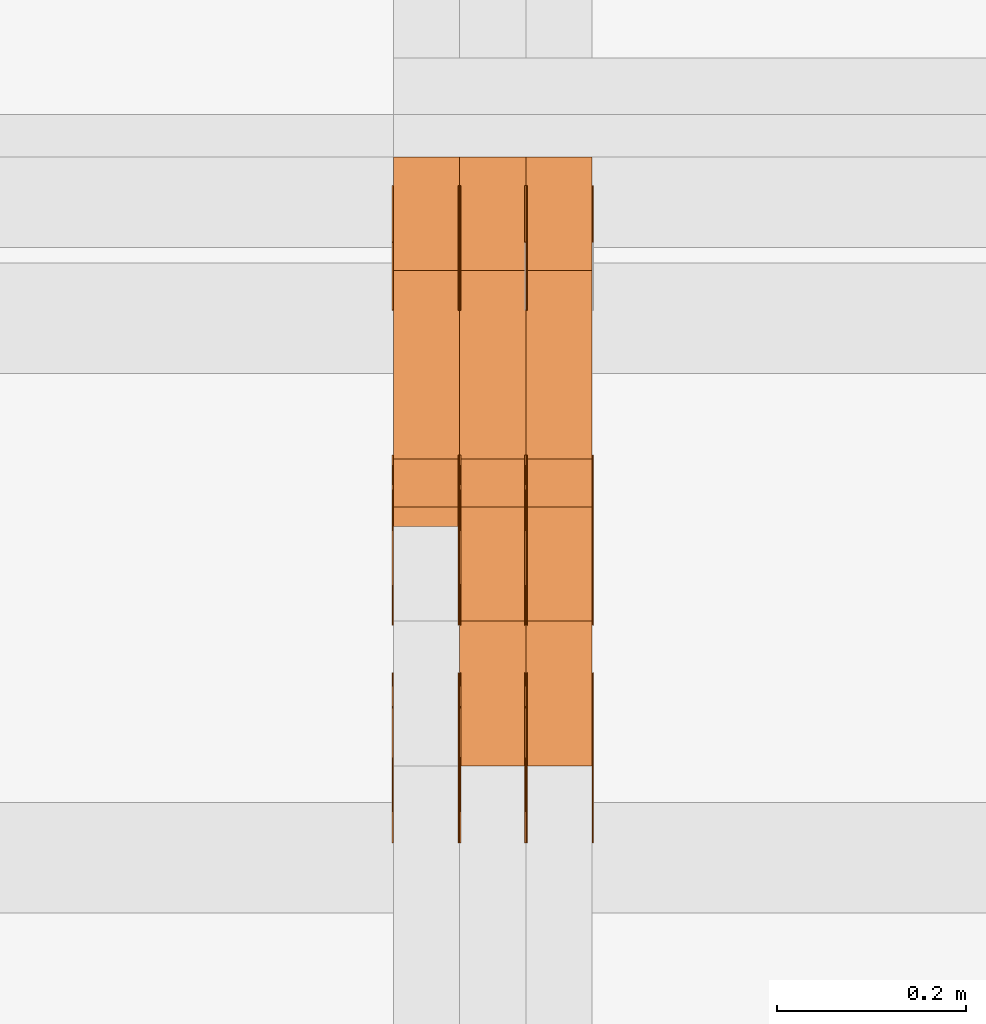
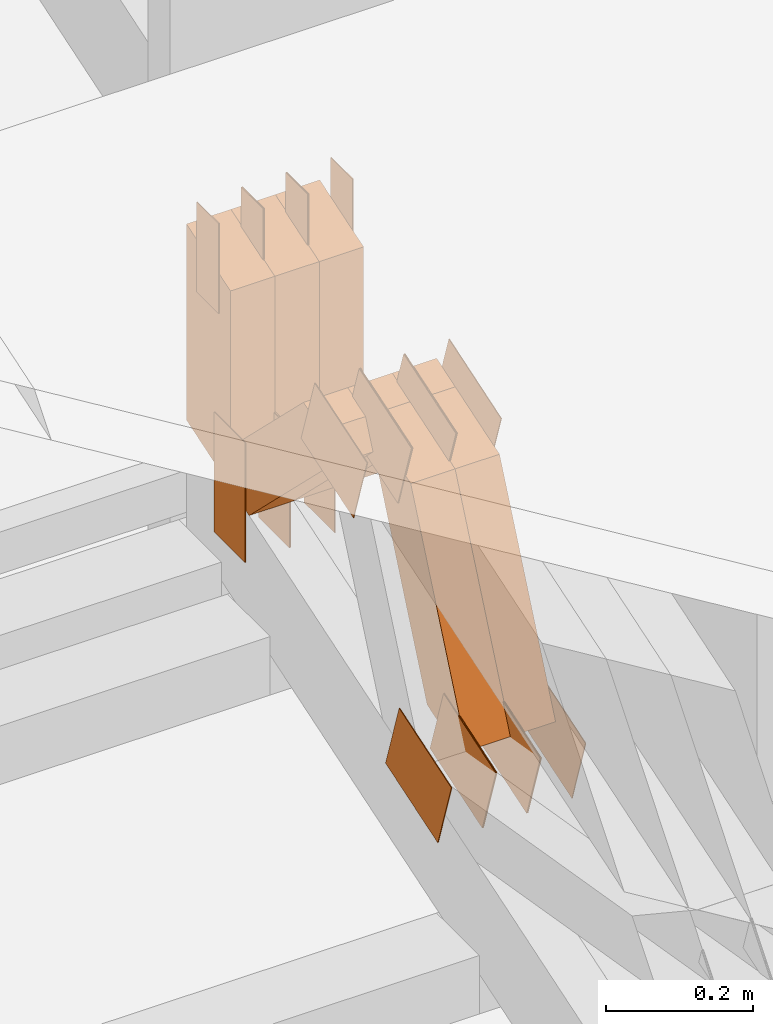
# One storey, part 92 of 385: 30 proxies.
"""IFC2X3 building model written with IfcOpenShell, lengths in millimetres."""

from ifc_helpers import new_model, entity, si_unit, converted_unit, derived_unit, direction, frame, frame_2d, origin, origin_2d_with_axis, place, context, subcontext, project, spatial, polyline, rectangle, outline, extrude, source, transform, mapped, material, type_object, type_shapes, element, save


model = new_model("IFC2X3")

# Units and contexts
model_context = context("Model", 3, precision=0.01, world=origin(), true_north=direction((6.12303176911189e-17, 1.0)))
body_context = subcontext(model_context, "Body", "Model", "MODEL_VIEW")
ifc_project = project(units=[si_unit("LENGTHUNIT", "METRE", prefix="MILLI"), si_unit("AREAUNIT", "SQUARE_METRE"), si_unit("VOLUMEUNIT", "CUBIC_METRE"), converted_unit("PLANEANGLEUNIT", "DEGREE", entity("IfcRatioMeasure", 0.0174532925199433), si_unit("PLANEANGLEUNIT", "RADIAN"), dimensions=[0, 0, 0, 0, 0, 0, 0]), si_unit("MASSUNIT", "GRAM", prefix="KILO"), derived_unit("MASSDENSITYUNIT", [(si_unit("MASSUNIT", "GRAM", prefix="KILO"), 1), (si_unit("LENGTHUNIT", "METRE"), -3)]), si_unit("TIMEUNIT", "SECOND"), si_unit("FREQUENCYUNIT", "HERTZ"), si_unit("THERMODYNAMICTEMPERATUREUNIT", "DEGREE_CELSIUS"), derived_unit("THERMALTRANSMITTANCEUNIT", [(si_unit("MASSUNIT", "GRAM", prefix="KILO"), 1), (si_unit("THERMODYNAMICTEMPERATUREUNIT", "KELVIN"), -1), (si_unit("TIMEUNIT", "SECOND"), -3)]), derived_unit("VOLUMETRICFLOWRATEUNIT", [(si_unit("LENGTHUNIT", "METRE"), 3), (si_unit("TIMEUNIT", "SECOND"), -1)]), si_unit("ELECTRICCURRENTUNIT", "AMPERE"), si_unit("ELECTRICVOLTAGEUNIT", "VOLT"), si_unit("POWERUNIT", "WATT"), si_unit("FORCEUNIT", "NEWTON", prefix="KILO"), si_unit("ILLUMINANCEUNIT", "LUX"), si_unit("LUMINOUSFLUXUNIT", "LUMEN"), si_unit("LUMINOUSINTENSITYUNIT", "CANDELA"), derived_unit("USERDEFINED", [(si_unit("MASSUNIT", "GRAM", prefix="KILO"), -1), (si_unit("LENGTHUNIT", "METRE"), -2), (si_unit("TIMEUNIT", "SECOND"), 3), (si_unit("LUMINOUSFLUXUNIT", "LUMEN"), 1)]), derived_unit("LINEARVELOCITYUNIT", [(si_unit("LENGTHUNIT", "METRE"), 1), (si_unit("TIMEUNIT", "SECOND"), -1)]), si_unit("PRESSUREUNIT", "PASCAL"), derived_unit("USERDEFINED", [(si_unit("LENGTHUNIT", "METRE"), -2), (si_unit("MASSUNIT", "GRAM", prefix="KILO"), 1), (si_unit("TIMEUNIT", "SECOND"), -2)])], contexts=[model_context])

# Site, building, storey
site_placement = place(None, origin())
site = spatial("IfcSite", under=ifc_project, at=site_placement, CompositionType="ELEMENT")
building_placement = place(site_placement, origin())
building = spatial("IfcBuilding", under=site, at=building_placement, CompositionType="ELEMENT")
storey_placement = place(building_placement, origin())
storey = spatial("IfcBuildingStorey", under=building, at=storey_placement, Name="Default", CompositionType="ELEMENT", Elevation=0.0)

# Proxies
ifc_material_1 = material(Name="IfcSurfaceStyle #140162")
building_element_proxy_type_1 = type_object("IfcBuildingElementProxyType", PredefinedType="NOTDEFINED", material=ifc_material_1)
shared_shape_1 = source(origin(), body_context, "Body", "SweptSolid", [
    extrude(rectangle(XDim=200.0, YDim=84.0, at=frame_2d((0.0, -7.105427357601e-15), x_axis=(1.0, 0.0))), frame((100.0, 42.0, 0.0), z_axis=(0.0, 0.0, 1.0), x_axis=(-1.0, 0.0, 0.0)), (0.0, 0.0, 1.0), 1.3),
])
type_shapes(building_element_proxy_type_1, [shared_shape_1])
proxy_1_placement = place(building_placement, frame((9316.29999999998, 13702.0, 3651.4150390625), z_axis=(-1.0, 0.0, 0.0), x_axis=(0.0, 0.0, -1.0)))
element("IfcBuildingElementProxy", 1, at=proxy_1_placement, inside=storey, type_object=building_element_proxy_type_1, material=ifc_material_1, context=body_context, shape_type="MappedRepresentation", body=[
    mapped(shared_shape_1, transform((0.0, 0.0, 0.0), scale=1.0)),
])
ifc_material_2 = material(Name="IfcSurfaceStyle #140105")
building_element_proxy_type_2 = type_object("IfcBuildingElementProxyType", PredefinedType="NOTDEFINED", material=ifc_material_2)
shared_shape_2 = source(origin(), body_context, "Body", "SweptSolid", [
    extrude(rectangle(XDim=200.0, YDim=84.0, at=frame_2d((0.0, -7.105427357601e-15), x_axis=(1.0, 0.0))), frame((100.0, 42.0, 0.0), z_axis=(0.0, 0.0, 1.0), x_axis=(-1.0, 0.0, 0.0)), (0.0, 0.0, 1.0), 1.29999999999998),
])
type_shapes(building_element_proxy_type_2, [shared_shape_2])
proxy_2_placement = place(building_placement, frame((9245.0, 13702.0, 3651.4150390625), z_axis=(-1.0, 0.0, 0.0), x_axis=(0.0, 0.0, -1.0)))
element("IfcBuildingElementProxy", 2, at=proxy_2_placement, inside=storey, type_object=building_element_proxy_type_2, material=ifc_material_2, context=body_context, shape_type="MappedRepresentation", body=[
    mapped(shared_shape_2, transform((0.0, 0.0, 0.0), scale=1.0)),
])
ifc_material_3 = material(Name="IfcSurfaceStyle #140048")
building_element_proxy_type_3 = type_object("IfcBuildingElementProxyType", PredefinedType="NOTDEFINED", material=ifc_material_3)
shared_shape_3 = source(origin(), body_context, "Body", "SweptSolid", [
    extrude(rectangle(XDim=200.0, YDim=84.0, at=frame_2d((0.0, -7.105427357601e-15), x_axis=(1.0, 0.0))), frame((100.0, 42.0, 0.0), z_axis=(0.0, 0.0, 1.0), x_axis=(-1.0, 0.0, 0.0)), (0.0, 0.0, 1.0), 1.29999999999998),
])
type_shapes(building_element_proxy_type_3, [shared_shape_3])
proxy_3_placement = place(building_placement, frame((9246.29999999998, 13702.0, 3651.4150390625), z_axis=(-1.0, 0.0, 0.0), x_axis=(0.0, 0.0, -1.0)))
element("IfcBuildingElementProxy", 3, at=proxy_3_placement, inside=storey, type_object=building_element_proxy_type_3, material=ifc_material_3, context=body_context, shape_type="MappedRepresentation", body=[
    mapped(shared_shape_3, transform((0.0, 0.0, 0.0), scale=1.0)),
])
ifc_material_4 = material(Name="IfcSurfaceStyle #139991")
building_element_proxy_type_4 = type_object("IfcBuildingElementProxyType", PredefinedType="NOTDEFINED", material=ifc_material_4)
shared_shape_4 = source(origin(), body_context, "Body", "SweptSolid", [
    extrude(rectangle(XDim=200.0, YDim=84.0, at=frame_2d((0.0, -7.105427357601e-15), x_axis=(1.0, 0.0))), frame((100.0, 42.0, 0.0), z_axis=(0.0, 0.0, 1.0), x_axis=(-1.0, 0.0, 0.0)), (0.0, 0.0, 1.0), 1.29999999999999),
])
type_shapes(building_element_proxy_type_4, [shared_shape_4])
proxy_4_placement = place(building_placement, frame((9175.0, 13702.0, 3651.4150390625), z_axis=(-1.0, 0.0, 0.0), x_axis=(0.0, 0.0, -1.0)))
element("IfcBuildingElementProxy", 4, at=proxy_4_placement, inside=storey, type_object=building_element_proxy_type_4, material=ifc_material_4, context=body_context, shape_type="MappedRepresentation", body=[
    mapped(shared_shape_4, transform((0.0, 0.0, 0.0), scale=1.0)),
])
ifc_material_5 = material(Name="IfcSurfaceStyle #139934")
building_element_proxy_type_5 = type_object("IfcBuildingElementProxyType", PredefinedType="NOTDEFINED", material=ifc_material_5)
shared_shape_5 = source(origin(), body_context, "Body", "SweptSolid", [
    extrude(outline(polyline([(-75.0003398116828, -59.9998507501386), (75.0003249421766, -59.9998507501386), (75.0003398116837, 59.9998507501387), (-75.0003249421775, 59.9998507501387), (-75.0003398116828, -59.9998507501386)])), frame((75.0003398116837, 60.0000773549637, 0.0), z_axis=(0.0, 0.0, 1.0), x_axis=(-1.0, 0.0, 0.0)), (0.0, 0.0, 1.0), 1.3),
])
type_shapes(building_element_proxy_type_5, [shared_shape_5])
proxy_5_placement = place(building_placement, frame((9386.29999999998, 13054.73046875, 3417.8388671875), z_axis=(-1.0, 0.0, 0.0), x_axis=(0.0, 0.951056516295124, 0.309016994375039)))
element("IfcBuildingElementProxy", 5, at=proxy_5_placement, inside=storey, type_object=building_element_proxy_type_5, material=ifc_material_5, context=body_context, shape_type="MappedRepresentation", body=[
    mapped(shared_shape_5, transform((0.0, 0.0, 0.0), scale=1.0)),
])
ifc_material_6 = material(Name="IfcSurfaceStyle #139877")
building_element_proxy_type_6 = type_object("IfcBuildingElementProxyType", PredefinedType="NOTDEFINED", material=ifc_material_6)
shared_shape_6 = source(origin(), body_context, "Body", "SweptSolid", [
    extrude(outline(polyline([(-75.0003398116828, -59.9998507501386), (75.0003249421766, -59.9998507501386), (75.0003398116837, 59.9998507501387), (-75.0003249421775, 59.9998507501387), (-75.0003398116828, -59.9998507501386)])), frame((75.0003398116837, 60.0000773549637, 0.0), z_axis=(0.0, 0.0, 1.0), x_axis=(-1.0, 0.0, 0.0)), (0.0, 0.0, 1.0), 1.3),
])
type_shapes(building_element_proxy_type_6, [shared_shape_6])
proxy_6_placement = place(building_placement, frame((9315.0, 13054.73046875, 3417.8388671875), z_axis=(-1.0, 0.0, 0.0), x_axis=(0.0, 0.951056516295124, 0.309016994375039)))
element("IfcBuildingElementProxy", 6, at=proxy_6_placement, inside=storey, type_object=building_element_proxy_type_6, material=ifc_material_6, context=body_context, shape_type="MappedRepresentation", body=[
    mapped(shared_shape_6, transform((0.0, 0.0, 0.0), scale=1.0)),
])
ifc_material_7 = material(Name="IfcSurfaceStyle #139820")
building_element_proxy_type_7 = type_object("IfcBuildingElementProxyType", PredefinedType="NOTDEFINED", material=ifc_material_7)
shared_shape_7 = source(origin(), body_context, "Body", "SweptSolid", [
    extrude(outline(polyline([(-75.0003398116828, -59.9998507501386), (75.0003249421766, -59.9998507501386), (75.0003398116837, 59.9998507501387), (-75.0003249421775, 59.9998507501387), (-75.0003398116828, -59.9998507501386)])), frame((75.0003398116837, 60.0000773549637, 0.0), z_axis=(0.0, 0.0, 1.0), x_axis=(-1.0, 0.0, 0.0)), (0.0, 0.0, 1.0), 1.3),
])
type_shapes(building_element_proxy_type_7, [shared_shape_7])
proxy_7_placement = place(building_placement, frame((9316.29999999998, 13054.73046875, 3417.8388671875), z_axis=(-1.0, 0.0, 0.0), x_axis=(0.0, 0.951056516295124, 0.309016994375039)))
element("IfcBuildingElementProxy", 7, at=proxy_7_placement, inside=storey, type_object=building_element_proxy_type_7, material=ifc_material_7, context=body_context, shape_type="MappedRepresentation", body=[
    mapped(shared_shape_7, transform((0.0, 0.0, 0.0), scale=1.0)),
])
ifc_material_8 = material(Name="IfcSurfaceStyle #139763")
building_element_proxy_type_8 = type_object("IfcBuildingElementProxyType", PredefinedType="NOTDEFINED", material=ifc_material_8)
shared_shape_8 = source(origin(), body_context, "Body", "SweptSolid", [
    extrude(outline(polyline([(-75.0003398116828, -59.9998507501386), (75.0003249421766, -59.9998507501386), (75.0003398116837, 59.9998507501387), (-75.0003249421775, 59.9998507501387), (-75.0003398116828, -59.9998507501386)])), frame((75.0003398116837, 60.0000773549637, 0.0), z_axis=(0.0, 0.0, 1.0), x_axis=(-1.0, 0.0, 0.0)), (0.0, 0.0, 1.0), 1.29999999999999),
])
type_shapes(building_element_proxy_type_8, [shared_shape_8])
proxy_8_placement = place(building_placement, frame((9245.0, 13054.73046875, 3417.8388671875), z_axis=(-1.0, 0.0, 0.0), x_axis=(0.0, 0.951056516295124, 0.309016994375039)))
element("IfcBuildingElementProxy", 8, at=proxy_8_placement, inside=storey, type_object=building_element_proxy_type_8, material=ifc_material_8, context=body_context, shape_type="MappedRepresentation", body=[
    mapped(shared_shape_8, transform((0.0, 0.0, 0.0), scale=1.0)),
])
ifc_material_9 = material(Name="IfcSurfaceStyle #139706")
building_element_proxy_type_9 = type_object("IfcBuildingElementProxyType", PredefinedType="NOTDEFINED", material=ifc_material_9)
shared_shape_9 = source(origin(), body_context, "Body", "SweptSolid", [
    extrude(outline(polyline([(-75.0003398116828, -59.9998507501386), (75.0003249421766, -59.9998507501386), (75.0003398116837, 59.9998507501387), (-75.0003249421775, 59.9998507501387), (-75.0003398116828, -59.9998507501386)])), frame((75.0003398116837, 60.0000773549637, 0.0), z_axis=(0.0, 0.0, 1.0), x_axis=(-1.0, 0.0, 0.0)), (0.0, 0.0, 1.0), 1.29999999999999),
])
type_shapes(building_element_proxy_type_9, [shared_shape_9])
proxy_9_placement = place(building_placement, frame((9246.29999999998, 13054.73046875, 3417.8388671875), z_axis=(-1.0, 0.0, 0.0), x_axis=(0.0, 0.951056516295124, 0.309016994375039)))
element("IfcBuildingElementProxy", 9, at=proxy_9_placement, inside=storey, type_object=building_element_proxy_type_9, material=ifc_material_9, context=body_context, shape_type="MappedRepresentation", body=[
    mapped(shared_shape_9, transform((0.0, 0.0, 0.0), scale=1.0)),
])
ifc_material_10 = material(Name="IfcSurfaceStyle #139649")
building_element_proxy_type_10 = type_object("IfcBuildingElementProxyType", PredefinedType="NOTDEFINED", material=ifc_material_10)
shared_shape_10 = source(origin(), body_context, "Body", "SweptSolid", [
    extrude(outline(polyline([(-75.0003398116828, -59.9998507501386), (75.0003249421766, -59.9998507501386), (75.0003398116837, 59.9998507501387), (-75.0003249421775, 59.9998507501387), (-75.0003398116828, -59.9998507501386)])), frame((75.0003398116837, 60.0000773549637, 0.0), z_axis=(0.0, 0.0, 1.0), x_axis=(-1.0, 0.0, 0.0)), (0.0, 0.0, 1.0), 1.29999999999999),
])
type_shapes(building_element_proxy_type_10, [shared_shape_10])
proxy_10_placement = place(building_placement, frame((9175.0, 13054.73046875, 3417.8388671875), z_axis=(-1.0, 0.0, 0.0), x_axis=(0.0, 0.951056516295124, 0.309016994375039)))
element("IfcBuildingElementProxy", 10, at=proxy_10_placement, inside=storey, type_object=building_element_proxy_type_10, material=ifc_material_10, context=body_context, shape_type="MappedRepresentation", body=[
    mapped(shared_shape_10, transform((0.0, 0.0, 0.0), scale=1.0)),
])
ifc_material_11 = material(Name="IfcSurfaceStyle #132068")
building_element_proxy_type_11 = type_object("IfcBuildingElementProxyType", PredefinedType="NOTDEFINED", material=ifc_material_11)
shared_shape_11 = source(origin(), body_context, "Body", "SweptSolid", [
    extrude(outline(polyline([(-74.999875428623, -60.0000016373506), (74.9998605591059, -60.0000016373506), (74.9998754286239, 60.0000016373506), (-74.9998605591068, 60.0000016373506), (-74.999875428623, -60.0000016373506)])), frame((75.0002691827262, 60.0000190504561, 0.0), z_axis=(0.0, 0.0, 1.0), x_axis=(-1.0, 0.0, 0.0)), (0.0, 0.0, 1.0), 1.3),
])
type_shapes(building_element_proxy_type_11, [shared_shape_11])
proxy_11_placement = place(building_placement, frame((9386.29999999998, 13285.0865109705, 3819.37496637467), z_axis=(-1.0, 0.0, 0.0), x_axis=(0.0, 0.951056516295154, 0.309016994374948)))
element("IfcBuildingElementProxy", 11, at=proxy_11_placement, inside=storey, type_object=building_element_proxy_type_11, material=ifc_material_11, context=body_context, shape_type="MappedRepresentation", body=[
    mapped(shared_shape_11, transform((0.0, 0.0, 0.0), scale=1.0)),
])
ifc_material_12 = material(Name="IfcSurfaceStyle #132011")
building_element_proxy_type_12 = type_object("IfcBuildingElementProxyType", PredefinedType="NOTDEFINED", material=ifc_material_12)
shared_shape_12 = source(origin(), body_context, "Body", "SweptSolid", [
    extrude(outline(polyline([(-74.999875428623, -60.0000016373506), (74.9998605591059, -60.0000016373506), (74.9998754286239, 60.0000016373506), (-74.9998605591068, 60.0000016373506), (-74.999875428623, -60.0000016373506)])), frame((75.0002691827262, 60.0000190504561, 0.0), z_axis=(0.0, 0.0, 1.0), x_axis=(-1.0, 0.0, 0.0)), (0.0, 0.0, 1.0), 1.3),
])
type_shapes(building_element_proxy_type_12, [shared_shape_12])
proxy_12_placement = place(building_placement, frame((9315.0, 13285.0865109705, 3819.37496637467), z_axis=(-1.0, 0.0, 0.0), x_axis=(0.0, 0.951056516295154, 0.309016994374948)))
element("IfcBuildingElementProxy", 12, at=proxy_12_placement, inside=storey, type_object=building_element_proxy_type_12, material=ifc_material_12, context=body_context, shape_type="MappedRepresentation", body=[
    mapped(shared_shape_12, transform((0.0, 0.0, 0.0), scale=1.0)),
])
ifc_material_13 = material(Name="IfcSurfaceStyle #131954")
building_element_proxy_type_13 = type_object("IfcBuildingElementProxyType", PredefinedType="NOTDEFINED", material=ifc_material_13)
shared_shape_13 = source(origin(), body_context, "Body", "SweptSolid", [
    extrude(outline(polyline([(-74.999875428623, -60.0000016373506), (74.9998605591059, -60.0000016373506), (74.9998754286239, 60.0000016373506), (-74.9998605591068, 60.0000016373506), (-74.999875428623, -60.0000016373506)])), frame((75.0002691827262, 60.0000190504561, 0.0), z_axis=(0.0, 0.0, 1.0), x_axis=(-1.0, 0.0, 0.0)), (0.0, 0.0, 1.0), 1.3),
])
type_shapes(building_element_proxy_type_13, [shared_shape_13])
proxy_13_placement = place(building_placement, frame((9316.29999999998, 13285.0865109705, 3819.37496637467), z_axis=(-1.0, 0.0, 0.0), x_axis=(0.0, 0.951056516295154, 0.309016994374948)))
element("IfcBuildingElementProxy", 13, at=proxy_13_placement, inside=storey, type_object=building_element_proxy_type_13, material=ifc_material_13, context=body_context, shape_type="MappedRepresentation", body=[
    mapped(shared_shape_13, transform((0.0, 0.0, 0.0), scale=1.0)),
])
ifc_material_14 = material(Name="IfcSurfaceStyle #131897")
building_element_proxy_type_14 = type_object("IfcBuildingElementProxyType", PredefinedType="NOTDEFINED", material=ifc_material_14)
shared_shape_14 = source(origin(), body_context, "Body", "SweptSolid", [
    extrude(outline(polyline([(-74.999875428623, -60.0000016373506), (74.9998605591059, -60.0000016373506), (74.9998754286239, 60.0000016373506), (-74.9998605591068, 60.0000016373506), (-74.999875428623, -60.0000016373506)])), frame((75.0002691827262, 60.0000190504561, 0.0), z_axis=(0.0, 0.0, 1.0), x_axis=(-1.0, 0.0, 0.0)), (0.0, 0.0, 1.0), 1.29999999999999),
])
type_shapes(building_element_proxy_type_14, [shared_shape_14])
proxy_14_placement = place(building_placement, frame((9245.0, 13285.0865109705, 3819.37496637467), z_axis=(-1.0, 0.0, 0.0), x_axis=(0.0, 0.951056516295154, 0.309016994374948)))
element("IfcBuildingElementProxy", 14, at=proxy_14_placement, inside=storey, type_object=building_element_proxy_type_14, material=ifc_material_14, context=body_context, shape_type="MappedRepresentation", body=[
    mapped(shared_shape_14, transform((0.0, 0.0, 0.0), scale=1.0)),
])
ifc_material_15 = material(Name="IfcSurfaceStyle #131840")
building_element_proxy_type_15 = type_object("IfcBuildingElementProxyType", PredefinedType="NOTDEFINED", material=ifc_material_15)
shared_shape_15 = source(origin(), body_context, "Body", "SweptSolid", [
    extrude(outline(polyline([(-74.999875428623, -60.0000016373506), (74.9998605591059, -60.0000016373506), (74.9998754286239, 60.0000016373506), (-74.9998605591068, 60.0000016373506), (-74.999875428623, -60.0000016373506)])), frame((75.0002691827262, 60.0000190504561, 0.0), z_axis=(0.0, 0.0, 1.0), x_axis=(-1.0, 0.0, 0.0)), (0.0, 0.0, 1.0), 1.29999999999999),
])
type_shapes(building_element_proxy_type_15, [shared_shape_15])
proxy_15_placement = place(building_placement, frame((9246.29999999998, 13285.0865109705, 3819.37496637467), z_axis=(-1.0, 0.0, 0.0), x_axis=(0.0, 0.951056516295154, 0.309016994374948)))
element("IfcBuildingElementProxy", 15, at=proxy_15_placement, inside=storey, type_object=building_element_proxy_type_15, material=ifc_material_15, context=body_context, shape_type="MappedRepresentation", body=[
    mapped(shared_shape_15, transform((0.0, 0.0, 0.0), scale=1.0)),
])
ifc_material_16 = material(Name="IfcSurfaceStyle #131783")
building_element_proxy_type_16 = type_object("IfcBuildingElementProxyType", PredefinedType="NOTDEFINED", material=ifc_material_16)
shared_shape_16 = source(origin(), body_context, "Body", "SweptSolid", [
    extrude(outline(polyline([(-74.999875428623, -60.0000016373506), (74.9998605591059, -60.0000016373506), (74.9998754286239, 60.0000016373506), (-74.9998605591068, 60.0000016373506), (-74.999875428623, -60.0000016373506)])), frame((75.0002691827262, 60.0000190504561, 0.0), z_axis=(0.0, 0.0, 1.0), x_axis=(-1.0, 0.0, 0.0)), (0.0, 0.0, 1.0), 1.29999999999999),
])
type_shapes(building_element_proxy_type_16, [shared_shape_16])
proxy_16_placement = place(building_placement, frame((9175.0, 13285.0865109705, 3819.37496637467), z_axis=(-1.0, 0.0, 0.0), x_axis=(0.0, 0.951056516295154, 0.309016994374948)))
element("IfcBuildingElementProxy", 16, at=proxy_16_placement, inside=storey, type_object=building_element_proxy_type_16, material=ifc_material_16, context=body_context, shape_type="MappedRepresentation", body=[
    mapped(shared_shape_16, transform((0.0, 0.0, 0.0), scale=1.0)),
])
ifc_material_17 = material(Name="IfcSurfaceStyle #131384")
building_element_proxy_type_17 = type_object("IfcBuildingElementProxyType", PredefinedType="NOTDEFINED", material=ifc_material_17)
shared_shape_17 = source(origin(), body_context, "Body", "SweptSolid", [
    extrude(rectangle(XDim=150.0, YDim=60.0, at=origin_2d_with_axis()), frame((75.0000705696166, 30.0, 0.0), z_axis=(0.0, 0.0, 1.0), x_axis=(-1.0, 0.0, 0.0)), (0.0, 0.0, 1.0), 1.3),
])
type_shapes(building_element_proxy_type_17, [shared_shape_17])
proxy_17_placement = place(building_placement, frame((9386.29999999998, 13750.0, 3972.59919166337), z_axis=(-1.0, 0.0, 0.0), x_axis=(0.0, 0.0, -1.0)))
element("IfcBuildingElementProxy", 17, at=proxy_17_placement, inside=storey, type_object=building_element_proxy_type_17, material=ifc_material_17, context=body_context, shape_type="MappedRepresentation", body=[
    mapped(shared_shape_17, transform((0.0, 0.0, 0.0), scale=1.0)),
])
ifc_material_18 = material(Name="IfcSurfaceStyle #131327")
building_element_proxy_type_18 = type_object("IfcBuildingElementProxyType", PredefinedType="NOTDEFINED", material=ifc_material_18)
shared_shape_18 = source(origin(), body_context, "Body", "SweptSolid", [
    extrude(rectangle(XDim=150.0, YDim=60.0, at=origin_2d_with_axis()), frame((75.0000705696166, 30.0, 0.0), z_axis=(0.0, 0.0, 1.0), x_axis=(-1.0, 0.0, 0.0)), (0.0, 0.0, 1.0), 1.3),
])
type_shapes(building_element_proxy_type_18, [shared_shape_18])
proxy_18_placement = place(building_placement, frame((9315.0, 13750.0, 3972.59919166337), z_axis=(-1.0, 0.0, 0.0), x_axis=(0.0, 0.0, -1.0)))
element("IfcBuildingElementProxy", 18, at=proxy_18_placement, inside=storey, type_object=building_element_proxy_type_18, material=ifc_material_18, context=body_context, shape_type="MappedRepresentation", body=[
    mapped(shared_shape_18, transform((0.0, 0.0, 0.0), scale=1.0)),
])
ifc_material_19 = material(Name="IfcSurfaceStyle #131270")
building_element_proxy_type_19 = type_object("IfcBuildingElementProxyType", PredefinedType="NOTDEFINED", material=ifc_material_19)
shared_shape_19 = source(origin(), body_context, "Body", "SweptSolid", [
    extrude(rectangle(XDim=150.0, YDim=60.0, at=origin_2d_with_axis()), frame((75.0000705696166, 30.0, 0.0), z_axis=(0.0, 0.0, 1.0), x_axis=(-1.0, 0.0, 0.0)), (0.0, 0.0, 1.0), 1.3),
])
type_shapes(building_element_proxy_type_19, [shared_shape_19])
proxy_19_placement = place(building_placement, frame((9316.29999999998, 13750.0, 3972.59919166337), z_axis=(-1.0, 0.0, 0.0), x_axis=(0.0, 0.0, -1.0)))
element("IfcBuildingElementProxy", 19, at=proxy_19_placement, inside=storey, type_object=building_element_proxy_type_19, material=ifc_material_19, context=body_context, shape_type="MappedRepresentation", body=[
    mapped(shared_shape_19, transform((0.0, 0.0, 0.0), scale=1.0)),
])
ifc_material_20 = material(Name="IfcSurfaceStyle #131213")
building_element_proxy_type_20 = type_object("IfcBuildingElementProxyType", PredefinedType="NOTDEFINED", material=ifc_material_20)
shared_shape_20 = source(origin(), body_context, "Body", "SweptSolid", [
    extrude(rectangle(XDim=150.0, YDim=60.0, at=origin_2d_with_axis()), frame((75.0000705696166, 30.0, 0.0), z_axis=(0.0, 0.0, 1.0), x_axis=(-1.0, 0.0, 0.0)), (0.0, 0.0, 1.0), 1.29999999999999),
])
type_shapes(building_element_proxy_type_20, [shared_shape_20])
proxy_20_placement = place(building_placement, frame((9245.0, 13750.0, 3972.59919166337), z_axis=(-1.0, 0.0, 0.0), x_axis=(0.0, 0.0, -1.0)))
element("IfcBuildingElementProxy", 20, at=proxy_20_placement, inside=storey, type_object=building_element_proxy_type_20, material=ifc_material_20, context=body_context, shape_type="MappedRepresentation", body=[
    mapped(shared_shape_20, transform((0.0, 0.0, 0.0), scale=1.0)),
])
ifc_material_21 = material(Name="IfcSurfaceStyle #131156")
building_element_proxy_type_21 = type_object("IfcBuildingElementProxyType", PredefinedType="NOTDEFINED", material=ifc_material_21)
shared_shape_21 = source(origin(), body_context, "Body", "SweptSolid", [
    extrude(rectangle(XDim=150.0, YDim=60.0, at=origin_2d_with_axis()), frame((75.0000705696166, 30.0, 0.0), z_axis=(0.0, 0.0, 1.0), x_axis=(-1.0, 0.0, 0.0)), (0.0, 0.0, 1.0), 1.29999999999999),
])
type_shapes(building_element_proxy_type_21, [shared_shape_21])
proxy_21_placement = place(building_placement, frame((9246.29999999998, 13750.0, 3972.59919166337), z_axis=(-1.0, 0.0, 0.0), x_axis=(0.0, 0.0, -1.0)))
element("IfcBuildingElementProxy", 21, at=proxy_21_placement, inside=storey, type_object=building_element_proxy_type_21, material=ifc_material_21, context=body_context, shape_type="MappedRepresentation", body=[
    mapped(shared_shape_21, transform((0.0, 0.0, 0.0), scale=1.0)),
])
ifc_material_22 = material(Name="IfcSurfaceStyle #131099")
building_element_proxy_type_22 = type_object("IfcBuildingElementProxyType", PredefinedType="NOTDEFINED", material=ifc_material_22)
shared_shape_22 = source(origin(), body_context, "Body", "SweptSolid", [
    extrude(rectangle(XDim=150.0, YDim=60.0, at=origin_2d_with_axis()), frame((75.0000705696166, 30.0, 0.0), z_axis=(0.0, 0.0, 1.0), x_axis=(-1.0, 0.0, 0.0)), (0.0, 0.0, 1.0), 1.29999999999999),
])
type_shapes(building_element_proxy_type_22, [shared_shape_22])
proxy_22_placement = place(building_placement, frame((9175.0, 13750.0, 3972.59919166337), z_axis=(-1.0, 0.0, 0.0), x_axis=(0.0, 0.0, -1.0)))
element("IfcBuildingElementProxy", 22, at=proxy_22_placement, inside=storey, type_object=building_element_proxy_type_22, material=ifc_material_22, context=body_context, shape_type="MappedRepresentation", body=[
    mapped(shared_shape_22, transform((0.0, 0.0, 0.0), scale=1.0)),
])
ifc_material_23 = material(Name="IfcSurfaceStyle #121898")
building_element_proxy_type_23 = type_object("IfcBuildingElementProxyType", Name="T1-W49 121896", PredefinedType="NOTDEFINED", material=ifc_material_23)
shared_shape_23 = source(origin(), body_context, "Body", "SweptSolid", [
    extrude(outline(polyline([(-155.175867306415, -47.4997478409253), (152.310664695054, -47.4997478409253), (170.496756790954, -6.14570120142345e-05), (145.70957993751, 47.4998092979374), (-133.37808995724, 47.4998092979373), (-179.963044159863, -6.14570120298391e-05), (-155.175867306415, -47.4997478409253)])), frame((170.496756790954, 47.5001152140455, 0.0), z_axis=(0.0, 0.0, 1.0), x_axis=(-1.0, 0.0, 0.0)), (0.0, 0.0, 1.0), 70.0),
])
type_shapes(building_element_proxy_type_23, [shared_shape_23])
proxy_23_placement = place(building_placement, frame((9385.0, 13443.048524104, 3830.71841973934), z_axis=(-1.0, 0.0, 0.0), x_axis=(0.0, 0.713950095632063, -0.700196587357413)))
element("IfcBuildingElementProxy", 23, at=proxy_23_placement, inside=storey, type_object=building_element_proxy_type_23, material=ifc_material_23, Name="T1-W49", context=body_context, shape_type="MappedRepresentation", body=[
    mapped(shared_shape_23, transform((0.0, 0.0, 0.0), scale=1.0)),
])
ifc_material_24 = material(Name="IfcSurfaceStyle #121823")
building_element_proxy_type_24 = type_object("IfcBuildingElementProxyType", Name="T1-W49 121821", PredefinedType="NOTDEFINED", material=ifc_material_24)
shared_shape_24 = source(origin(), body_context, "Body", "SweptSolid", [
    extrude(outline(polyline([(-155.175867306415, -47.4997478409253), (152.310664695054, -47.4997478409253), (170.496756790954, -6.14570120142345e-05), (145.70957993751, 47.4998092979374), (-133.37808995724, 47.4998092979373), (-179.963044159863, -6.14570120298391e-05), (-155.175867306415, -47.4997478409253)])), frame((170.496756790954, 47.5001152140455, 0.0), z_axis=(0.0, 0.0, 1.0), x_axis=(-1.0, 0.0, 0.0)), (0.0, 0.0, 1.0), 70.0),
])
type_shapes(building_element_proxy_type_24, [shared_shape_24])
proxy_24_placement = place(building_placement, frame((9315.0, 13443.048524104, 3830.71841973934), z_axis=(-1.0, 0.0, 0.0), x_axis=(0.0, 0.713950095632063, -0.700196587357413)))
element("IfcBuildingElementProxy", 24, at=proxy_24_placement, inside=storey, type_object=building_element_proxy_type_24, material=ifc_material_24, Name="T1-W49", context=body_context, shape_type="MappedRepresentation", body=[
    mapped(shared_shape_24, transform((0.0, 0.0, 0.0), scale=1.0)),
])
ifc_material_25 = material(Name="IfcSurfaceStyle #121748")
building_element_proxy_type_25 = type_object("IfcBuildingElementProxyType", Name="T1-W49 121746", PredefinedType="NOTDEFINED", material=ifc_material_25)
shared_shape_25 = source(origin(), body_context, "Body", "SweptSolid", [
    extrude(outline(polyline([(-155.175867306415, -47.4997478409253), (152.310664695054, -47.4997478409253), (170.496756790954, -6.14570120142345e-05), (145.70957993751, 47.4998092979374), (-133.37808995724, 47.4998092979373), (-179.963044159863, -6.14570120298391e-05), (-155.175867306415, -47.4997478409253)])), frame((170.496756790954, 47.5001152140455, 0.0), z_axis=(0.0, 0.0, 1.0), x_axis=(-1.0, 0.0, 0.0)), (0.0, 0.0, 1.0), 70.0),
])
type_shapes(building_element_proxy_type_25, [shared_shape_25])
proxy_25_placement = place(building_placement, frame((9245.0, 13443.048524104, 3830.71841973934), z_axis=(-1.0, 0.0, 0.0), x_axis=(0.0, 0.713950095632063, -0.700196587357413)))
element("IfcBuildingElementProxy", 25, at=proxy_25_placement, inside=storey, type_object=building_element_proxy_type_25, material=ifc_material_25, Name="T1-W49", context=body_context, shape_type="MappedRepresentation", body=[
    mapped(shared_shape_25, transform((0.0, 0.0, 0.0), scale=1.0)),
])
ifc_material_26 = material(Name="IfcSurfaceStyle #121448")
building_element_proxy_type_26 = type_object("IfcBuildingElementProxyType", Name="T1-W1 121446", PredefinedType="NOTDEFINED", material=ifc_material_26)
shared_shape_26 = source(origin(), body_context, "Body", "SweptSolid", [
    extrude(outline(polyline([(-182.839782714844, -60.0), (143.849426269531, -60.0), (182.839660644531, 60.0), (-143.849304199219, 60.0), (-182.839782714844, -60.0)])), frame((182.839674685549, 60.0, 0.0), z_axis=(0.0, 0.0, 1.0), x_axis=(-1.0, 0.0, 0.0)), (0.0, 0.0, 1.0), 70.0),
])
type_shapes(building_element_proxy_type_26, [shared_shape_26])
proxy_26_placement = place(building_placement, frame((9385.0, 13660.0, 3551.41502502148), z_axis=(-1.0, 0.0, 0.0), x_axis=(0.0, 0.0, 1.0)))
element("IfcBuildingElementProxy", 26, at=proxy_26_placement, inside=storey, type_object=building_element_proxy_type_26, material=ifc_material_26, Name="T1-W1", context=body_context, shape_type="MappedRepresentation", body=[
    mapped(shared_shape_26, transform((0.0, 0.0, 0.0), scale=1.0)),
])
ifc_material_27 = material(Name="IfcSurfaceStyle #121391")
building_element_proxy_type_27 = type_object("IfcBuildingElementProxyType", Name="T1-W1 121389", PredefinedType="NOTDEFINED", material=ifc_material_27)
shared_shape_27 = source(origin(), body_context, "Body", "SweptSolid", [
    extrude(outline(polyline([(-182.839782714844, -60.0), (143.849426269531, -60.0), (182.839660644531, 60.0), (-143.849304199219, 60.0), (-182.839782714844, -60.0)])), frame((182.839674685549, 60.0, 0.0), z_axis=(0.0, 0.0, 1.0), x_axis=(-1.0, 0.0, 0.0)), (0.0, 0.0, 1.0), 70.0),
])
type_shapes(building_element_proxy_type_27, [shared_shape_27])
proxy_27_placement = place(building_placement, frame((9315.0, 13660.0, 3551.41502502148), z_axis=(-1.0, 0.0, 0.0), x_axis=(0.0, 0.0, 1.0)))
element("IfcBuildingElementProxy", 27, at=proxy_27_placement, inside=storey, type_object=building_element_proxy_type_27, material=ifc_material_27, Name="T1-W1", context=body_context, shape_type="MappedRepresentation", body=[
    mapped(shared_shape_27, transform((0.0, 0.0, 0.0), scale=1.0)),
])
ifc_material_28 = material(Name="IfcSurfaceStyle #121334")
building_element_proxy_type_28 = type_object("IfcBuildingElementProxyType", Name="T1-W1 121332", PredefinedType="NOTDEFINED", material=ifc_material_28)
shared_shape_28 = source(origin(), body_context, "Body", "SweptSolid", [
    extrude(outline(polyline([(-182.839782714844, -60.0), (143.849426269531, -60.0), (182.839660644531, 60.0), (-143.849304199219, 60.0), (-182.839782714844, -60.0)])), frame((182.839674685549, 60.0, 0.0), z_axis=(0.0, 0.0, 1.0), x_axis=(-1.0, 0.0, 0.0)), (0.0, 0.0, 1.0), 70.0),
])
type_shapes(building_element_proxy_type_28, [shared_shape_28])
proxy_28_placement = place(building_placement, frame((9245.0, 13660.0, 3551.41502502148), z_axis=(-1.0, 0.0, 0.0), x_axis=(0.0, 0.0, 1.0)))
element("IfcBuildingElementProxy", 28, at=proxy_28_placement, inside=storey, type_object=building_element_proxy_type_28, material=ifc_material_28, Name="T1-W1", context=body_context, shape_type="MappedRepresentation", body=[
    mapped(shared_shape_28, transform((0.0, 0.0, 0.0), scale=1.0)),
])
ifc_material_29 = material(Name="IfcSurfaceStyle #120908")
building_element_proxy_type_29 = type_object("IfcBuildingElementProxyType", Name="T1-W42 120906", PredefinedType="NOTDEFINED", material=ifc_material_29)
shared_shape_29 = source(origin(), body_context, "Body", "SweptSolid", [
    extrude(outline(polyline([(-284.837590197601, -47.4997543607933), (129.95880168156, -47.4997543607933), (171.972324990451, 0.000162623346093338), (183.717007105413, 47.4996730491203), (-200.810543579822, 47.4996730491203), (-284.837590197601, -47.4997543607933)])), frame((183.717155718752, 47.4999821655365, 0.0), z_axis=(0.0, 0.0, 1.0), x_axis=(-1.0, 0.0, 0.0)), (0.0, 0.0, 1.0), 70.0),
])
type_shapes(building_element_proxy_type_29, [shared_shape_29])
proxy_29_placement = place(building_placement, frame((9385.0, 13135.8834463264, 3404.958483022), z_axis=(-1.0, 0.0, 0.0), x_axis=(0.0, 0.398630596470292, 0.917111578575769)))
element("IfcBuildingElementProxy", 29, at=proxy_29_placement, inside=storey, type_object=building_element_proxy_type_29, material=ifc_material_29, Name="T1-W42", context=body_context, shape_type="MappedRepresentation", body=[
    mapped(shared_shape_29, transform((0.0, 0.0, 0.0), scale=1.0)),
])
ifc_material_30 = material(Name="IfcSurfaceStyle #120842")
building_element_proxy_type_30 = type_object("IfcBuildingElementProxyType", Name="T1-W42 120840", PredefinedType="NOTDEFINED", material=ifc_material_30)
shared_shape_30 = source(origin(), body_context, "Body", "SweptSolid", [
    extrude(outline(polyline([(-284.837590197601, -47.4997543607933), (129.95880168156, -47.4997543607933), (171.972324990451, 0.000162623346093338), (183.717007105413, 47.4996730491203), (-200.810543579822, 47.4996730491203), (-284.837590197601, -47.4997543607933)])), frame((183.717155718752, 47.4999821655365, 0.0), z_axis=(0.0, 0.0, 1.0), x_axis=(-1.0, 0.0, 0.0)), (0.0, 0.0, 1.0), 70.0),
])
type_shapes(building_element_proxy_type_30, [shared_shape_30])
proxy_30_placement = place(building_placement, frame((9315.0, 13135.8834463264, 3404.958483022), z_axis=(-1.0, 0.0, 0.0), x_axis=(0.0, 0.398630596470292, 0.917111578575769)))
element("IfcBuildingElementProxy", 30, at=proxy_30_placement, inside=storey, type_object=building_element_proxy_type_30, material=ifc_material_30, Name="T1-W42", context=body_context, shape_type="MappedRepresentation", body=[
    mapped(shared_shape_30, transform((0.0, 0.0, 0.0), scale=1.0)),
])

save(model, "model.ifc")
